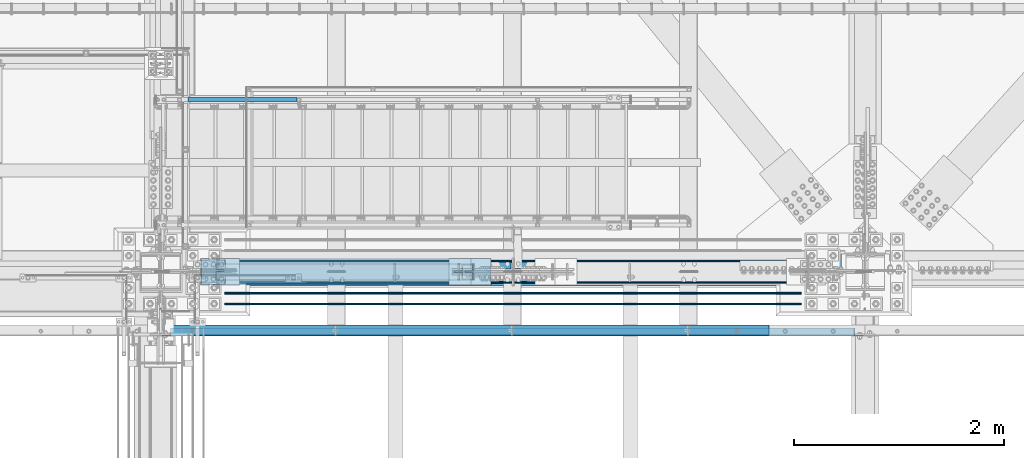
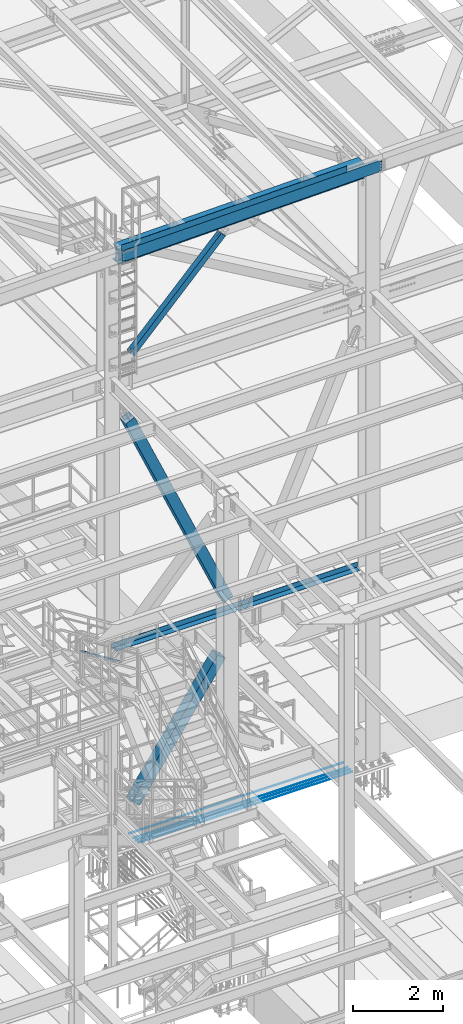
# One storey, part 1787 of 3843: 8 beams, 4 members, 11 elements without a shape of their own.
"""IFC2X3 building model written with IfcOpenShell, lengths in millimetres."""

from ifc_helpers import new_model, si_unit, frame, origin_with_axes, place, context, subcontext, project, spatial, faceted_brep, material, type_object, element, aggregate, save


model = new_model("IFC2X3")

# Units and contexts
model_context = context("Model", 3, precision=1e-05, world=origin_with_axes())
body_context = subcontext(model_context, "Body", "Model", "MODEL_VIEW")
ifc_project = project(units=[si_unit("LENGTHUNIT", "METRE", prefix="MILLI"), si_unit("AREAUNIT", "SQUARE_METRE"), si_unit("VOLUMEUNIT", "CUBIC_METRE"), si_unit("MASSUNIT", "GRAM", prefix="KILO"), si_unit("TIMEUNIT", "SECOND"), si_unit("PLANEANGLEUNIT", "RADIAN"), si_unit("SOLIDANGLEUNIT", "STERADIAN"), si_unit("THERMODYNAMICTEMPERATUREUNIT", "DEGREE_CELSIUS"), si_unit("LUMINOUSINTENSITYUNIT", "LUMEN")], contexts=[model_context])

# Site, building, storey
site_placement = place(None, origin_with_axes())
site = spatial("IfcSite", under=ifc_project, at=site_placement, CompositionType="ELEMENT")
building_placement = place(site_placement, origin_with_axes())
building = spatial("IfcBuilding", under=site, at=building_placement, Name="Undefined", CompositionType="ELEMENT")
storey_placement = place(building_placement, origin_with_axes())
storey = spatial("IfcBuildingStorey", under=building, at=storey_placement, Name="Undefined", CompositionType="ELEMENT", Elevation=0.0)

# Assembly, member
assembly_1_placement = place(storey_placement, origin_with_axes())
assembly_1 = element("IfcElementAssembly", 1, at=assembly_1_placement, inside=storey, Name="RAIL", AssemblyPlace="NOTDEFINED", PredefinedType="RIGID_FRAME")
ifc_material_1 = material()
member_type_1 = type_object("IfcMemberType", Name="HSS1-1/2X1-1/2X1/4", PredefinedType="NOTDEFINED")
member_1_placement = place(assembly_1_placement, frame((57245.2499999773, 27254.20000005, 33163.9934658526), z_axis=(0.533450437959022, 0.0, 0.845831324935018), x_axis=(-0.845831324935018, 0.0, 0.533450437959022)))
member_1 = element("IfcMember", 2, at=member_1_placement, type_object=member_type_1, material=ifc_material_1, Name="RAIL", ObjectType="HSS1-1/2X1-1/2X1/4", context=body_context, shape_type="Brep", body=[
    faceted_brep([(34.5367091819608, -19.0500003825, 19.0499992349214), (34.5367091819608, 19.0499992350015, 19.0499992349214), (10.507732870894, 19.0499992350015, -19.049999235016), (10.507732870894, -19.0499992350015, -19.049999235016), (30.5318796958745, -12.6999993300014, 12.699999329925), (14.5125623569802, -12.6999993300014, -12.6999993300269), (14.5125623569802, 12.6999993300014, -12.6999993300269), (30.5318796958745, 12.6999993300014, 12.699999329925), (1248.23146424039, 19.0499992350015, -19.0499992375117), (1248.23146424039, -19.0499992350015, -19.0499992375117), (1259.2424708534, -19.0499992350015, 19.0499992324476), (1259.2424708534, 19.0499992350015, 19.0499992324476), (1257.40730303832, -12.6999993300014, 12.6999993274512), (1257.40730303832, 12.6999993300014, 12.6999993274512), (1250.06663205547, 12.6999993300014, -12.6999993325153), (1250.06663205547, -12.6999993300014, -12.6999993325153)], [[[0, 1, 2, 3], [4, 5, 6, 7]], [[8, 9, 3, 2]], [[9, 10, 0, 3]], [[10, 11, 1, 0]], [[11, 8, 2, 1]], [[10, 9, 8, 11], [12, 13, 14, 15]], [[13, 12, 4, 7]], [[14, 13, 7, 6]], [[15, 14, 6, 5]], [[12, 15, 5, 4]]]),
])
aggregate(assembly_1, [member_1])

# Assembly, beam
assembly_2_placement = place(storey_placement, origin_with_axes())
assembly_2 = element("IfcElementAssembly", 3, at=assembly_2_placement, inside=storey, Name="BEAM", AssemblyPlace="NOTDEFINED", PredefinedType="RIGID_FRAME")
ifc_material_2 = material(Name="STEEL/A572-50")
beam_type_1 = type_object("IfcBeamType", Name="C12X20.7", PredefinedType="NOTDEFINED")
beam_1_placement = place(assembly_2_placement, frame((55927.4421007083, 25044.4000000723, 45986.575724375), z_axis=(0.0211520550054438, 0.0, -0.999776270257025), x_axis=(0.999776270257024, 0.0, 0.0211520550054619)))
beam_1 = element("IfcBeam", 4, at=beam_1_placement, type_object=beam_type_1, material=ifc_material_2, Name="BEAM", ObjectType="C12X20.7", context=body_context, shape_type="Brep", body=[
    faceted_brep([(6608.67788717993, -38.1000000000058, -146.047459993133), (6608.67788717994, -38.1000000000058, -152.399999993126), (6608.67788717994, 38.1000000000058, -152.399999993126), (6608.67788717993, 38.1000000000058, -139.699999804012), (6608.67788717993, 1.13523856271058e-06, -139.699999804012), (6609.64461710249, 38.1000000000058, -134.839920285995), (6609.64461710249, 30.1625000000058, -134.674927493157), (6612.39763100295, 38.1000000000058, -130.719743817848), (6612.39763100295, 30.1625000000058, -130.719743817848), (6616.51780747109, 38.1000000000058, -127.966729917382), (6616.51780747109, 30.1625000000058, -127.966729917382), (6621.37788698912, 38.1000000000058, -126.999999994805), (6621.37788698912, 30.1625000000058, -126.999999994805), (6691.22582736199, 30.1625000000058, -126.999999994725), (6691.22558853275, 38.1000000000058, -126.999999994725), (6608.67788717964, -38.1000000000058, 146.047460006397), (6608.67788717963, -38.1000000000058, 152.400000006382), (98.4250003414782, -38.1000000000058, 152.399999999863), (98.4250003414927, -38.1000000000058, 146.047459999871), (6608.67788717963, 38.1000000000058, 152.400000006382), (98.4250003414782, 38.1000000000058, 152.399999999863), (98.4250003414927, 38.1000000000058, 139.699999784301), (98.4250003414927, 1.29402906168252e-06, 139.699999784301), (98.4250003417692, 1.00112811196595e-06, -139.699999832876), (98.4250003417692, 38.1000000000058, -139.699999832876), (98.4250003417837, 38.1000000000058, -152.399999999638), (98.4250003417837, -38.1000000000058, -152.399999999638), (98.4250003417765, -38.1000000000058, -146.047459999652), (97.458270419178, 30.1625000000058, -134.674927499669), (97.4582704191853, 38.1000000000058, -134.839920314858), (94.7052565187187, 30.1625000000058, -130.719743846734), (94.7052565187187, 38.1000000000058, -130.719743846734), (90.5850800505723, 30.1625000000058, -127.966729946267), (90.5850800505723, 38.1000000000058, -127.966729946267), (85.725000532555, 30.1625000000058, -127.000000023691), (85.725000532555, 38.1000000000058, -127.000000023691), (15.8751814754869, 30.1625000000058, -127.000000049156), (15.8750003662499, 38.1000000000058, -127.000000023749), (15.87518425296, 30.1624999999985, -114.300000386182), (15.8751814814968, 30.1624999999985, 116.299999618452), (15.8751845281877, 30.1625000000058, 126.999999949614), (15.8750006201954, 38.1000000000058, 126.999999975014), (85.7250005323076, 30.1625000000058, 126.99999997508), (85.7250005323076, 38.1000000000058, 126.99999997508), (90.5850800503176, 30.1625000000058, 127.966729897671), (90.5850800503176, 38.1000000000058, 127.966729897671), (94.7052565184495, 30.1625000000058, 130.719743798138), (94.7052565184495, 38.1000000000058, 130.719743798138), (97.4582704189161, 30.1625000000058, 134.674927499887), (97.4582704189233, 38.1000000000058, 134.839920266269), (6609.64461710223, 30.1625000000058, 134.674927506407), (6608.67788717964, 1.15988950710744e-06, 139.699999813165), (6608.67788717964, 38.1000000000058, 139.699999813165), (6609.64461710223, 38.1000000000058, 134.83992029514), (6612.39763100271, 30.1625000000058, 130.719743827016), (6612.39763100271, 38.1000000000058, 130.719743827016), (6616.51780747084, 30.1625000000058, 127.966729926549), (6616.51780747084, 38.1000000000058, 127.966729926549), (6621.37788698886, 30.1625000000058, 127.00000000398), (6621.37788698886, 38.1000000000058, 127.00000000398), (6691.22583270017, 30.1625000000058, 127.000000004038), (6691.22559387093, 38.1000000000058, 127.000000004038), (6691.22582753254, 30.1624999999985, 116.300000724514), (6691.22583237893, 30.1624999999985, -114.299999268718)], [[[0, 1, 2, 3, 4]], [[4, 3, 5, 6]], [[6, 5, 7, 8]], [[8, 7, 9, 10]], [[10, 9, 11, 12]], [[13, 12, 11, 14]], [[15, 16, 17, 18]], [[16, 19, 20, 17]], [[17, 20, 21, 22, 18]], [[23, 24, 25, 26, 27]], [[28, 29, 24, 23]], [[30, 31, 29, 28]], [[32, 33, 31, 30]], [[34, 35, 33, 32]], [[36, 37, 35, 34]], [[38, 39, 40, 41, 37, 36]], [[42, 43, 41, 40]], [[44, 45, 43, 42]], [[46, 47, 45, 44]], [[48, 49, 47, 46]], [[22, 21, 49, 48]], [[48, 50, 51, 15, 18, 22]], [[16, 15, 51, 52, 19]], [[50, 53, 52, 51]], [[54, 55, 53, 50]], [[56, 57, 55, 54]], [[58, 59, 57, 56]], [[60, 61, 59, 58]], [[61, 60, 62, 63, 13, 14]], [[31, 33, 35, 37, 41, 43, 45, 47, 49, 21, 20, 19, 52, 53, 55, 57, 59, 61, 14, 11, 9, 7, 5, 3, 2, 25, 24, 29]], [[2, 1, 26, 25]], [[1, 0, 27, 26]], [[0, 4, 6, 28, 23, 27]], [[63, 62, 60, 58, 56, 54, 50, 48, 46, 44, 42, 40, 39, 38, 36, 34, 32, 30, 28, 6, 8, 10, 12, 13]]]),
])

assembly_3_placement = place(storey_placement, origin_with_axes())
assembly_3 = element("IfcElementAssembly", 5, at=assembly_3_placement, inside=storey, Name="REBAR", AssemblyPlace="NOTDEFINED", PredefinedType="RIGID_FRAME")
ifc_material_3 = material(Name="STEEL/A706-60")
beam_type_2 = type_object("IfcBeamType", Name="#10 REBAR", PredefinedType="NOTDEFINED")
beam_2_placement = place(assembly_3_placement, frame((56540.3999804674, 25311.1000122071, 29687.8375), z_axis=(0.0, 0.0, 1.0), x_axis=(1.0, 0.0, 0.0)))
beam_2 = element("IfcBeam", 6, at=beam_2_placement, type_object=beam_type_2, material=ifc_material_3, Name="REBAR", ObjectType="#10 REBAR", context=body_context, shape_type="Brep", body=[
    faceted_brep([(0.0, -7.9375, 0.0), (0.0, -5.61266007566883, -5.61266007566883), (5486.48749999408, -5.61266007566883, -5.61266007566883), (5486.48749999408, -7.9375, 0.0), (0.0, 0.0, -7.9375), (5486.48749999408, 0.0, -7.9375), (0.0, 5.61266007566883, -5.61266007566883), (5486.48749999408, 5.61266007566883, -5.61266007566883), (0.0, 7.9375, 0.0), (5486.48749999408, 7.9375, 0.0), (0.0, 5.61266007566883, 5.61266007566883), (5486.48749999408, 5.61266007566883, 5.61266007566883), (0.0, 0.0, 7.9375), (5486.48749999408, 0.0, 7.9375), (0.0, -5.61266007566883, 5.61266007566883), (5486.48749999408, -5.61266007566883, 5.61266007566883)], [[[0, 1, 2, 3]], [[1, 4, 5, 2]], [[4, 6, 7, 5]], [[6, 8, 9, 7]], [[8, 10, 11, 9]], [[10, 12, 13, 11]], [[12, 14, 15, 13]], [[14, 0, 3, 15]], [[5, 7, 9, 11, 13, 15, 3, 2]], [[14, 12, 10, 8, 6, 4, 1, 0]]]),
])
aggregate(assembly_3, [beam_2])

assembly_4_placement = place(storey_placement, origin_with_axes())
assembly_4 = element("IfcElementAssembly", 7, at=assembly_4_placement, inside=storey, Name="REBAR", AssemblyPlace="NOTDEFINED", PredefinedType="RIGID_FRAME")
beam_3_placement = place(assembly_4_placement, frame((56540.3999804674, 25412.7000122071, 29687.8375), z_axis=(0.0, 0.0, 1.0), x_axis=(1.0, 0.0, 0.0)))
beam_3 = element("IfcBeam", 8, at=beam_3_placement, type_object=beam_type_2, material=ifc_material_3, Name="REBAR", ObjectType="#10 REBAR", context=body_context, shape_type="Brep", body=[
    faceted_brep([(0.0, -7.9375, 0.0), (0.0, -5.61266007566883, -5.61266007566883), (5486.48749999408, -5.61266007566883, -5.61266007566883), (5486.48749999408, -7.9375, 0.0), (0.0, 0.0, -7.9375), (5486.48749999408, 0.0, -7.9375), (0.0, 5.61266007566883, -5.61266007566883), (5486.48749999408, 5.61266007566883, -5.61266007566883), (0.0, 7.9375, 0.0), (5486.48749999408, 7.9375, 0.0), (0.0, 5.61266007566883, 5.61266007566883), (5486.48749999408, 5.61266007566883, 5.61266007566883), (0.0, 0.0, 7.9375), (5486.48749999408, 0.0, 7.9375), (0.0, -5.61266007566883, 5.61266007566883), (5486.48749999408, -5.61266007566883, 5.61266007566883)], [[[0, 1, 2, 3]], [[1, 4, 5, 2]], [[4, 6, 7, 5]], [[6, 8, 9, 7]], [[8, 10, 11, 9]], [[10, 12, 13, 11]], [[12, 14, 15, 13]], [[14, 0, 3, 15]], [[5, 7, 9, 11, 13, 15, 3, 2]], [[14, 12, 10, 8, 6, 4, 1, 0]]]),
])
aggregate(assembly_4, [beam_3])

assembly_5_placement = place(storey_placement, origin_with_axes())
assembly_5 = element("IfcElementAssembly", 9, at=assembly_5_placement, inside=storey, Name="REBAR", AssemblyPlace="NOTDEFINED", PredefinedType="RIGID_FRAME")
beam_4_placement = place(assembly_5_placement, frame((56540.3999804674, 25514.3000122071, 29687.8375), z_axis=(0.0, 0.0, 1.0), x_axis=(1.0, 0.0, 0.0)))
beam_4 = element("IfcBeam", 10, at=beam_4_placement, type_object=beam_type_2, material=ifc_material_3, Name="REBAR", ObjectType="#10 REBAR", context=body_context, shape_type="Brep", body=[
    faceted_brep([(0.0, -7.9375, 0.0), (0.0, -5.61266007566883, -5.61266007566883), (5486.48749999408, -5.61266007566883, -5.61266007566883), (5486.48749999408, -7.9375, 0.0), (0.0, 0.0, -7.9375), (5486.48749999408, 0.0, -7.9375), (0.0, 5.61266007566883, -5.61266007566883), (5486.48749999408, 5.61266007566883, -5.61266007566883), (0.0, 7.9375, 0.0), (5486.48749999408, 7.9375, 0.0), (0.0, 5.61266007566883, 5.61266007566883), (5486.48749999408, 5.61266007566883, 5.61266007566883), (0.0, 0.0, 7.9375), (5486.48749999408, 0.0, 7.9375), (0.0, -5.61266007566883, 5.61266007566883), (5486.48749999408, -5.61266007566883, 5.61266007566883)], [[[0, 1, 2, 3]], [[1, 4, 5, 2]], [[4, 6, 7, 5]], [[6, 8, 9, 7]], [[8, 10, 11, 9]], [[10, 12, 13, 11]], [[12, 14, 15, 13]], [[14, 0, 3, 15]], [[5, 7, 9, 11, 13, 15, 3, 2]], [[14, 12, 10, 8, 6, 4, 1, 0]]]),
])
aggregate(assembly_5, [beam_4])

assembly_6_placement = place(storey_placement, origin_with_axes())
assembly_6 = element("IfcElementAssembly", 11, at=assembly_6_placement, inside=storey, Name="REBAR", AssemblyPlace="NOTDEFINED", PredefinedType="RIGID_FRAME")
beam_5_placement = place(assembly_6_placement, frame((56540.3999804674, 25717.5000122071, 29687.8375), z_axis=(0.0, 0.0, 1.0), x_axis=(1.0, 0.0, 0.0)))
beam_5 = element("IfcBeam", 12, at=beam_5_placement, type_object=beam_type_2, material=ifc_material_3, Name="REBAR", ObjectType="#10 REBAR", context=body_context, shape_type="Brep", body=[
    faceted_brep([(0.0, -7.9375, 0.0), (0.0, -5.61266007566883, -5.61266007566883), (5486.48749999408, -5.61266007566883, -5.61266007566883), (5486.48749999408, -7.9375, 0.0), (0.0, 0.0, -7.9375), (5486.48749999408, 0.0, -7.9375), (0.0, 5.61266007566883, -5.61266007566883), (5486.48749999408, 5.61266007566883, -5.61266007566883), (0.0, 7.9375, 0.0), (5486.48749999408, 7.9375, 0.0), (0.0, 5.61266007566883, 5.61266007566883), (5486.48749999408, 5.61266007566883, 5.61266007566883), (0.0, 0.0, 7.9375), (5486.48749999408, 0.0, 7.9375), (0.0, -5.61266007566883, 5.61266007566883), (5486.48749999408, -5.61266007566883, 5.61266007566883)], [[[0, 1, 2, 3]], [[1, 4, 5, 2]], [[4, 6, 7, 5]], [[6, 8, 9, 7]], [[8, 10, 11, 9]], [[10, 12, 13, 11]], [[12, 14, 15, 13]], [[14, 0, 3, 15]], [[5, 7, 9, 11, 13, 15, 3, 2]], [[14, 12, 10, 8, 6, 4, 1, 0]]]),
])
aggregate(assembly_6, [beam_5])

# Beam
ifc_material_4 = material(Name="STEEL/A36")
beam_type_3 = type_object("IfcBeamType", PredefinedType="NOTDEFINED")
beam_6_placement = place(assembly_2_placement, frame((58827.5157866498, 25107.8999997034, 46203.5419038791), z_axis=(0.999776270257024, 0.0, 0.0211520550054619), x_axis=(0.0, -1.0, 0.0)))
beam_6 = element("IfcBeam", 13, at=beam_6_placement, type_object=beam_type_3, material=ifc_material_4, Name="BENT_PLATE", context=body_context, shape_type="Brep", body=[
    faceted_brep([(2.11002770811319e-10, -3.1749999970998, -2895.5999999953), (-2.18278728425503e-10, -3.17500000290602, 2895.59999999533), (-2.11002770811319e-10, 3.17499999707798, 2895.59999999533), (2.18278728425503e-10, 3.17500000289147, -2895.59999999531), (101.599999047587, 3.17499999699066, 2895.59999999533), (101.599999048274, 3.17500000279688, -2895.5999999953), (95.2499990734032, -3.17499999718711, -2895.5999999953), (95.2499990727156, -3.17500000299333, 2895.59999999533), (101.599999700979, -161.925000916817, 2895.59999999518), (101.599999701637, -161.925000911338, -2895.59999999544), (95.2499997009763, -161.925000941941, 2895.59999999518), (95.2499997016348, -161.92500093647, -2895.59999999545)], [[[0, 1, 2, 3]], [[3, 2, 4, 5]], [[1, 0, 6, 7]], [[5, 4, 8, 9]], [[4, 2, 1, 7, 10, 8]], [[7, 6, 11, 10]], [[6, 0, 3, 5, 9, 11]], [[10, 11, 9, 8]]]),
])

aggregate(assembly_2, [beam_1, beam_6])

# Assembly, member
assembly_7_placement = place(storey_placement, origin_with_axes())
assembly_7 = element("IfcElementAssembly", 14, at=assembly_7_placement, inside=storey, Name="None", AssemblyPlace="NOTDEFINED", PredefinedType="RIGID_FRAME")
ifc_material_5 = material(Name="STEEL/A992")
member_type_2 = type_object("IfcMemberType", Name="HSS10X10X1/4", PredefinedType="NOTDEFINED")
member_2_placement = place(assembly_7_placement, frame((56574.0860105301, 25615.9, 30620.8485316846), z_axis=(0.0, -1.0, 0.0), x_axis=(0.564372610296811, 0.0, 0.825520173434159)))
member_2 = element("IfcMember", 15, at=member_2_placement, type_object=member_type_2, material=ifc_material_5, Name="None", ObjectType="HSS10X10X1/4", context=body_context, shape_type="Brep", body=[
    faceted_brep([(2.00088834390044e-10, 120.650000000089, -120.649999999994), (-2.03726813197136e-10, -120.650000000081, -120.649999999994), (3905.24999997879, -120.649999992253, -120.650000000001), (3905.24999997883, 120.650000006994, -120.650000000001), (-2.03726813197136e-10, -120.650000000081, 120.649999999994), (3905.24999997879, -120.649999992253, 120.650000000001), (2.00088834390044e-10, 120.650000000089, 120.649999999994), (3905.24999997883, 120.650000006994, 120.650000000001), (2.16459739021957e-10, 127.000000000087, -127.0), (2.16459739021957e-10, 127.000000000087, 127.0), (3905.24999997883, 127.000000006985, 127.0), (3905.24999997883, 127.000000006985, -127.0), (-2.14640749618411e-10, -127.00000000008, 127.0), (3905.24999997879, -126.999999992244, 127.0), (-2.14640749618411e-10, -127.00000000008, -127.0), (3905.24999997879, -126.999999992244, -127.0)], [[[0, 1, 2, 3]], [[1, 4, 5, 2]], [[4, 6, 7, 5]], [[6, 0, 3, 7]], [[8, 9, 10, 11]], [[9, 12, 13, 10]], [[12, 14, 15, 13]], [[14, 8, 11, 15]], [[13, 15, 11, 10], [5, 7, 3, 2]], [[14, 12, 9, 8], [6, 4, 1, 0]]]),
])
aggregate(assembly_7, [member_2])

assembly_8_placement = place(storey_placement, origin_with_axes())
assembly_8 = element("IfcElementAssembly", 16, at=assembly_8_placement, inside=storey, Name="None", AssemblyPlace="NOTDEFINED", PredefinedType="RIGID_FRAME")
member_3_placement = place(assembly_8_placement, frame((58958.1479547192, 25615.9, 35326.2583484998), z_axis=(0.0, 1.0, 0.0), x_axis=(-0.402959140980662, 0.0, 0.915217968956099)))
member_3 = element("IfcMember", 17, at=member_3_placement, type_object=member_type_2, material=ifc_material_5, Name="None", ObjectType="HSS10X10X1/4", context=body_context, shape_type="Brep", body=[
    faceted_brep([(2.00088834390044e-10, 120.650000000089, -120.649999999994), (-2.03726813197136e-10, -120.650000000081, -120.649999999994), (6280.15037608392, -120.649999997302, -120.650000000001), (6280.15037608382, 120.650000003043, -120.650000000001), (-2.03726813197136e-10, -120.650000000081, 120.649999999994), (6280.15037608392, -120.649999997302, 120.650000000001), (2.00088834390044e-10, 120.650000000089, 120.649999999994), (6280.15037608382, 120.650000003043, 120.650000000001), (2.16459739021957e-10, 127.000000000087, -127.0), (2.16459739021957e-10, 127.000000000087, 127.0), (6280.1503760838, 127.000000003049, 127.0), (6280.1503760838, 127.000000003049, -127.0), (-2.14640749618411e-10, -127.00000000008, 127.0), (6280.15037608392, -126.999999997315, 127.0), (-2.14640749618411e-10, -127.00000000008, -127.0), (6280.15037608392, -126.999999997315, -127.0)], [[[0, 1, 2, 3]], [[1, 4, 5, 2]], [[4, 6, 7, 5]], [[6, 0, 3, 7]], [[8, 9, 10, 11]], [[9, 12, 13, 10]], [[12, 14, 15, 13]], [[14, 8, 11, 15]], [[13, 15, 11, 10], [5, 7, 3, 2]], [[14, 12, 9, 8], [6, 4, 1, 0]]]),
])
aggregate(assembly_8, [member_3])

# Assembly, beam
assembly_9_placement = place(storey_placement, origin_with_axes())
assembly_9 = element("IfcElementAssembly", 18, at=assembly_9_placement, inside=storey, Name="BEAM", AssemblyPlace="NOTDEFINED", PredefinedType="RIGID_FRAME")
beam_type_4 = type_object("IfcBeamType", PredefinedType="NOTDEFINED")
beam_7_placement = place(assembly_9_placement, frame((59284.394, 25641.3, 34813.875), z_axis=(-1.0, 0.0, 0.0), x_axis=(0.0, 1.0, 0.0)))
beam_7 = element("IfcBeam", 19, at=beam_7_placement, type_object=beam_type_4, material=ifc_material_4, Name="BENT_PLATE", context=body_context, shape_type="Brep", body=[
    faceted_brep([(57.1499999999978, -3.17500000000291, -19.0497493042494), (57.1499999999978, 3.17500000000291, -19.0497493042494), (0.0, 3.17500000000291, -19.0497493042494), (0.0, -3.17500000000291, -19.0497493042494), (57.1499999999869, -3.17500000000291, 19.0502506957491), (57.1499999999869, 3.17500000000291, 19.0502506957491), (0.0, -3.17500000000291, 19.0502506957491), (0.0, 3.17500000000291, 19.0502506957491), (146.049999999996, -3.17500000000291, 3126.58149999996), (146.049999999977, 3.17500000000291, 3126.58149999996), (0.0, 3.17500000000291, 3126.58149999997), (0.0, -3.17500000000291, 3126.58149999997), (146.049999999996, -3.17500000000291, 3158.33149999999), (146.049999999996, 3.17500000000291, 3158.3315), (146.049999999996, -136.524999999994, 3158.3315), (152.399999999994, -136.524999999994, 3158.3315), (152.399999999994, 3.17500000000291, 3158.3315), (152.399999999994, 3.17500000000291, -3158.3315), (152.399999999994, -136.524999999994, -3158.3315), (146.049999999996, -136.524999999994, 3126.58149999996), (146.049999999996, -136.524999999994, -3126.58149999999), (146.049999999996, -136.524999999994, -3158.3315), (146.050000000017, -3.17500000000291, -3126.58149999999), (146.049999999996, -3.17500000000291, -3158.3315), (146.049999999999, 3.17500000000291, -3158.3315), (146.050000000017, 3.17500000000291, -3126.58149999999), (0.0, -3.17500000000291, -3126.58149999998), (0.0, 3.17500000000291, -3126.58149999998)], [[[0, 1, 2, 3]], [[4, 5, 1, 0]], [[6, 7, 5, 4]], [[8, 9, 10, 11]], [[12, 13, 9, 8]], [[14, 15, 16, 13, 12]], [[17, 16, 15, 18]], [[14, 19, 20, 21, 18, 15]], [[12, 8, 22, 23, 21, 20, 19, 14]], [[17, 18, 21, 23, 24]], [[22, 25, 24, 23]], [[26, 27, 25, 22]], [[27, 26, 3, 2]], [[10, 9, 13, 16, 17, 24, 25, 27, 2, 1, 5, 7]], [[11, 10, 7, 6]], [[3, 26, 22, 8, 11, 6, 4, 0]]]),
])
aggregate(assembly_9, [beam_7])

# Assembly, member
assembly_10_placement = place(storey_placement, origin_with_axes())
assembly_10 = element("IfcElementAssembly", 20, at=assembly_10_placement, inside=storey, AssemblyPlace="NOTDEFINED", PredefinedType="RIGID_FRAME")
ifc_material_6 = material()
member_type_3 = type_object("IfcMemberType", Name="HSS6X6X3/8", PredefinedType="NOTDEFINED")
member_4_placement = place(assembly_10_placement, frame((55930.8, 25615.8999998765, 42197.3375), z_axis=(0.721481345122366, 0.0, -0.692433873117442), x_axis=(0.692433873117446, 0.0, 0.721481345122362)))
member_4 = element("IfcMember", 21, at=member_4_placement, type_object=member_type_3, material=ifc_material_6, ObjectType="HSS6X6X3/8", context=body_context, shape_type="Brep", body=[
    faceted_brep([(4219.59950864415, 7.9375, 76.2000000078933), (4119.58700864414, 7.9375, 76.2000000077114), (4119.58700864417, 7.9375, 66.6750000077063), (4219.59950864415, 7.9375, 66.6750000078991), (4116.54945889975, 7.33329378931376, 76.2000000077041), (4116.54945889977, 7.33329378931376, 66.6750000077063), (4113.97434856847, 5.61266007566883, 76.2000000076932), (4113.97434856849, 5.61266007566883, 66.6750000076991), (4112.25371485483, 3.0375497444038, 76.2000000076896), (4112.25371485486, 3.0375497444038, 66.6750000076918), (4111.64950864414, 0.0, 76.2000000076932), (4111.64950864416, 0.0, 66.6750000076881), (4112.25371485483, -3.0375497444038, 76.2000000076896), (4112.25371485486, -3.0375497444038, 66.6750000076918), (4113.97434856847, -5.61266007566883, 76.2000000076932), (4113.97434856849, -5.61266007566883, 66.6750000076991), (4116.54945889975, -7.33329378931376, 76.2000000077041), (4116.54945889977, -7.33329378931376, 66.6750000077063), (4119.58700864414, -7.9375, 76.2000000077114), (4119.58700864417, -7.9375, 66.6750000077063), (4219.59950864415, -7.9375, 76.2000000078933), (4219.59950864415, -7.9375, 66.6750000078991), (4219.59950864417, 7.9375, -66.6749999920958), (4119.5870086444, 7.9375, -66.6749999922777), (4119.58700864443, 7.9375, -76.1999999922755), (4219.59950864415, 7.9375, -76.1999999920972), (4116.54945890002, 7.33329378931376, -66.6749999922849), (4116.54945890003, 7.33329378931376, -76.1999999922828), (4113.97434856875, 5.61266007566883, -66.6749999922849), (4113.97434856876, 5.61266007566883, -76.19999999229), (4112.25371485511, 3.0375497444038, -66.6749999922922), (4112.25371485512, 3.0375497444038, -76.19999999229), (4111.6495086444, 0.0, -66.6749999922922), (4111.64950864443, 0.0, -76.19999999229), (4112.25371485511, -3.0375497444038, -66.6749999922922), (4112.25371485512, -3.0375497444038, -76.19999999229), (4113.97434856875, -5.61266007566883, -66.6749999922849), (4113.97434856876, -5.61266007566883, -76.19999999229), (4116.54945890002, -7.33329378931376, -66.6749999922849), (4116.54945890003, -7.33329378931376, -76.1999999922828), (4119.5870086444, -7.9375, -66.6749999922777), (4119.58700864443, -7.9375, -76.1999999922755), (4219.59950864417, -7.9375, -66.6749999920958), (4219.59950864415, -7.9375, -76.1999999920972), (840.293354128517, 66.6750000000029, 66.6750000015727), (840.293354128502, 66.6750000000029, -66.6749999984186), (4219.59950864417, 66.6750000000029, -66.6749999920958), (4219.59950864415, 66.6750000000029, 66.6750000078991), (4219.59950864415, -66.6750000000029, 66.6750000078991), (840.293354128517, -66.6750000000029, 66.6750000015727), (840.293354128517, -20.6374999999971, 66.6750000015727), (940.305854130318, -20.6374999999971, 66.675000001751), (943.343403874722, -20.0332937893108, 66.6750000017582), (945.918514205987, -18.3126600756659, 66.6750000017619), (947.639147919617, -15.7375497444009, 66.6750000017728), (948.243354130318, -12.6999999999971, 66.6750000017728), (947.639147919617, -9.66245025559328, 66.6750000017728), (945.918514205987, -7.08733992432826, 66.6750000017619), (943.343403874722, -5.36670621068333, 66.6750000017582), (940.305854130318, -4.76249999999709, 66.675000001751), (840.293354128517, -4.76249999999709, 66.6750000015727), (840.293354128502, -66.6750000000029, -66.6749999984186), (4219.59950864417, -66.6750000000029, -66.6749999920958), (840.293354128502, -4.76249999999709, -66.6749999984186), (940.305854130565, -4.76249999999709, -66.6749999982294), (943.343403874969, -5.36670621068333, -66.6749999982221), (945.918514206234, -7.08733992432826, -66.6749999982185), (947.639147919879, -9.66245025559328, -66.6749999982148), (948.24335413058, -12.6999999999971, -66.6749999982112), (947.639147919879, -15.7375497444009, -66.6749999982148), (945.918514206234, -18.3126600756659, -66.6749999982185), (943.343403874969, -20.0332937893108, -66.6749999982221), (940.305854130565, -20.6374999999971, -66.6749999982294), (840.293354128502, -20.6374999999971, -66.6749999984186), (840.293354128517, -4.76249999999709, -76.1999999984164), (940.30585413058, -4.76249999999709, -76.1999999982272), (943.343403874984, -5.36670621068333, -76.1999999982272), (945.918514206263, -7.08733992432826, -76.1999999982163), (947.639147919908, -9.66245025559328, -76.1999999982127), (948.243354130595, -12.6999999999971, -76.199999998209), (947.639147919908, -15.7375497444009, -76.1999999982127), (945.918514206263, -18.3126600756659, -76.1999999982163), (943.343403874984, -20.0332937893108, -76.1999999982272), (940.30585413058, -20.6374999999971, -76.1999999982272), (840.293354128517, -20.6374999999971, -76.1999999984164), (840.293354128517, -76.1999999999971, -76.1999999984164), (840.293354128517, -76.1999999999971, 76.2000000015669), (840.293354128517, -20.6374999999971, 76.2000000015669), (940.305854130318, -20.6374999999971, 76.2000000017561), (943.343403874707, -20.0332937893108, 76.2000000017561), (945.918514205972, -18.3126600756659, 76.200000001767), (947.639147919617, -15.7375497444009, 76.2000000017706), (948.243354130303, -12.6999999999971, 76.200000001767), (947.639147919617, -9.66245025559328, 76.2000000017706), (945.918514205972, -7.08733992432826, 76.200000001767), (943.343403874707, -5.36670621068333, 76.2000000017561), (940.305854130318, -4.76249999999709, 76.2000000017561), (840.293354128517, -4.76249999999709, 76.2000000015669), (840.293354128517, 76.1999999999971, 76.2000000015669), (840.293354128517, 76.1999999999971, -76.1999999984164), (4219.59950864415, 76.1999999999971, 76.2000000078933), (4219.59950864415, 76.1999999999971, -76.1999999920972), (4219.59950864415, -76.1999999999971, -76.1999999920972), (4219.59950864415, -76.1999999999971, 76.2000000078933)], [[[0, 1, 2, 3]], [[4, 5, 2, 1]], [[6, 7, 5, 4]], [[8, 9, 7, 6]], [[10, 11, 9, 8]], [[12, 13, 11, 10]], [[14, 15, 13, 12]], [[16, 17, 15, 14]], [[18, 19, 17, 16]], [[20, 21, 19, 18]], [[22, 23, 24, 25]], [[26, 27, 24, 23]], [[28, 29, 27, 26]], [[30, 31, 29, 28]], [[32, 33, 31, 30]], [[34, 35, 33, 32]], [[36, 37, 35, 34]], [[38, 39, 37, 36]], [[40, 41, 39, 38]], [[42, 43, 41, 40]], [[44, 45, 46, 47]], [[48, 49, 50, 51, 52, 53, 54, 55, 56, 57, 58, 59, 60, 44, 47, 3, 2, 5, 7, 9, 11, 13, 15, 17, 19, 21]], [[61, 49, 48, 62]], [[38, 36, 34, 32, 30, 28, 26, 23, 22, 46, 45, 63, 64, 65, 66, 67, 68, 69, 70, 71, 72, 73, 61, 62, 42, 40]], [[63, 74, 75, 64]], [[64, 75, 76, 65]], [[65, 76, 77, 66]], [[66, 77, 78, 67]], [[67, 78, 79, 68]], [[68, 79, 80, 69]], [[69, 80, 81, 70]], [[70, 81, 82, 71]], [[71, 82, 83, 72]], [[72, 83, 84, 73]], [[49, 61, 73, 84, 85, 86, 87, 50]], [[88, 51, 50, 87]], [[89, 52, 51, 88]], [[90, 53, 52, 89]], [[91, 54, 53, 90]], [[92, 55, 54, 91]], [[93, 56, 55, 92]], [[94, 57, 56, 93]], [[95, 58, 57, 94]], [[96, 59, 58, 95]], [[97, 60, 59, 96]], [[98, 99, 74, 63, 45, 44, 60, 97]], [[99, 98, 100, 101]], [[47, 46, 22, 25, 101, 100, 0, 3]], [[102, 85, 84, 83, 82, 81, 80, 79, 78, 77, 76, 75, 74, 99, 101, 25, 24, 27, 29, 31, 33, 35, 37, 39, 41, 43]], [[86, 85, 102, 103]], [[16, 14, 12, 10, 8, 6, 4, 1, 0, 100, 98, 97, 96, 95, 94, 93, 92, 91, 90, 89, 88, 87, 86, 103, 20, 18]], [[103, 102, 43, 42, 62, 48, 21, 20]]]),
])
aggregate(assembly_10, [member_4])

# Assembly, beam
assembly_11_placement = place(storey_placement, origin_with_axes())
assembly_11 = element("IfcElementAssembly", 22, at=assembly_11_placement, inside=storey, Name="BEAM", AssemblyPlace="NOTDEFINED", PredefinedType="RIGID_FRAME")
beam_type_5 = type_object("IfcBeamType", Name="W16X67", PredefinedType="NOTDEFINED")
beam_8_placement = place(assembly_11_placement, frame((55935.1988429476, 25615.9, 45619.9452773368), z_axis=(-0.0211520980073474, 0.0, 0.999776269347241), x_axis=(0.999776270257024, 0.0, 0.0211520550054619)))
beam_8 = element("IfcBeam", 23, at=beam_8_placement, type_object=beam_type_5, material=ifc_material_5, Name="BEAM", ObjectType="W16X67", context=body_context, shape_type="Brep", body=[
    faceted_brep([(189.682251619379, -130.174999999999, -207.962499999463), (189.682251619379, 130.174999999999, -207.962499999463), (6501.40687772939, 130.174999999999, -207.962499993126), (6501.40687772939, -130.174999999999, -207.962499993126), (190.051702788383, -130.174999999999, -190.499999999498), (190.051702788383, -4.76250000000073, -190.499999999498), (198.112455566654, -4.76250000000073, 190.499999999898), (198.112455566654, -130.174999999999, 190.499999999898), (198.481906735658, -130.174999999999, 207.96249999987), (198.481906735658, 130.174999999999, 207.96249999987), (198.112455566654, 130.174999999999, 190.499999999898), (198.112455566654, 4.76250000000073, 190.499999999898), (197.577240412233, 4.76250000000073, 165.202490022406), (190.830144189866, 4.76250000000073, -153.70614437294), (190.051702788383, 4.76250000000073, -190.499999999498), (190.051702788383, 130.174999999999, -190.499999999498), (6501.77632889838, -130.174999999999, -190.499999993161), (6501.77632889838, -4.76250000000073, -190.499999993161), (6509.83708167665, -4.76250000000073, 190.500000006235), (6509.83708167665, -130.174999999999, 190.500000006235), (6510.20653284565, -130.174999999999, 207.962500006208), (6510.20653284565, 130.174999999999, 207.962500006208), (6509.83708167665, 130.174999999999, 190.500000006235), (6509.83708167665, 4.76250000000073, 190.500000006235), (6509.26208276118, 4.76250000000073, 163.322068512527), (6502.51498653882, 4.76250000000073, -155.586565882819), (6501.77632889838, 4.76250000000073, -190.499999993161), (6501.77632889838, 130.174999999999, -190.499999993161)], [[[0, 1, 2, 3]], [[0, 4, 5, 6, 7, 8, 9, 10, 11, 12, 13, 14, 15, 1]], [[5, 4, 16, 17]], [[6, 5, 17, 18]], [[7, 6, 18, 19]], [[8, 7, 19, 20]], [[9, 8, 20, 21]], [[10, 9, 21, 22]], [[11, 10, 22, 23]], [[14, 13, 12, 11, 23, 24, 25, 26]], [[15, 14, 26, 27]], [[1, 15, 27, 2]], [[26, 25, 24, 23, 22, 21, 20, 19, 18, 17, 16, 3, 2, 27]], [[4, 0, 3, 16]]]),
])
aggregate(assembly_11, [beam_8])

save(model, "model.ifc")
